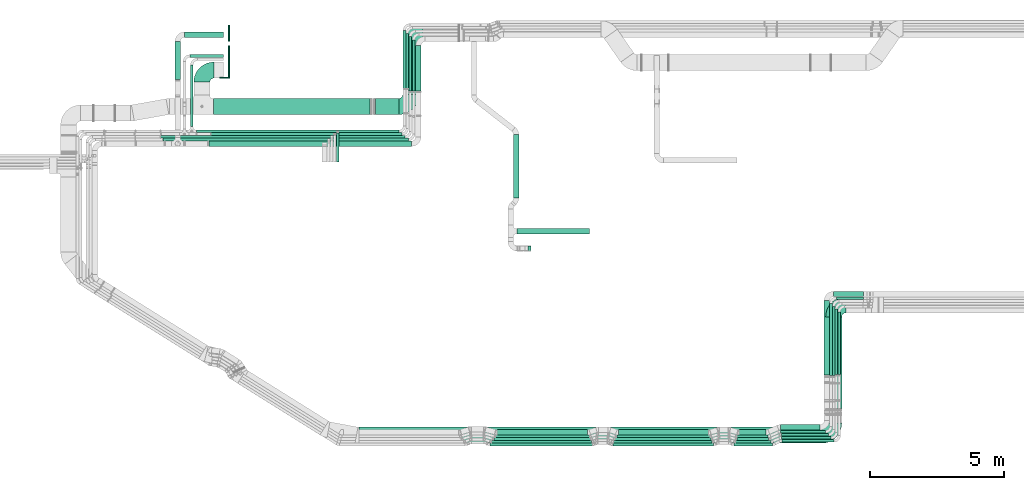
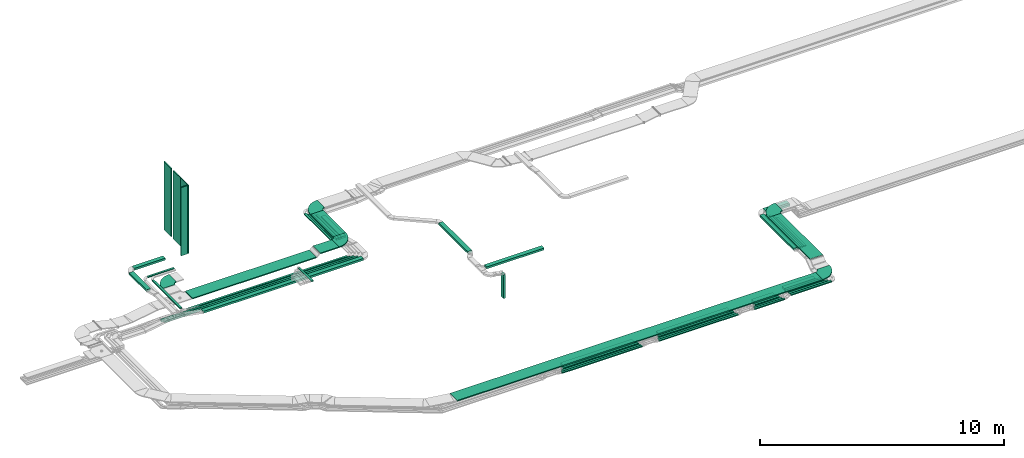
# One storey, part 5 of 38: 54 flow segments, 5 flow fittings.
"""IFC2X3 building model written with IfcOpenShell, lengths in millimetres."""

from ifc_helpers import new_model, entity, si_unit, converted_unit, derived_unit, direction, frame, frame_2d, origin, origin_2d_with_axis, place, context, subcontext, project, spatial, polyline, circle_curve, parameter, trimmed, segment, composite_curve, rectangle, outline, extrude, source, transform, mapped, material, type_object, type_shapes, element, save


model = new_model("IFC2X3")

# Units and contexts
model_context = context("Model", 3, precision=0.01, world=origin(), true_north=direction((6.12303176911189e-17, 1.0)))
body_context = subcontext(model_context, "Body", "Model", "MODEL_VIEW")
ifc_project = project(units=[si_unit("LENGTHUNIT", "METRE", prefix="MILLI"), si_unit("AREAUNIT", "SQUARE_METRE"), si_unit("VOLUMEUNIT", "CUBIC_METRE"), converted_unit("PLANEANGLEUNIT", "DEGREE", entity("IfcRatioMeasure", 0.0174532925199433), si_unit("PLANEANGLEUNIT", "RADIAN"), dimensions=[0, 0, 0, 0, 0, 0, 0]), si_unit("MASSUNIT", "GRAM", prefix="KILO"), derived_unit("MASSDENSITYUNIT", [(si_unit("MASSUNIT", "GRAM", prefix="KILO"), 1), (si_unit("LENGTHUNIT", "METRE"), -3)]), derived_unit("MOMENTOFINERTIAUNIT", [(si_unit("LENGTHUNIT", "METRE"), 4)]), si_unit("TIMEUNIT", "SECOND"), si_unit("FREQUENCYUNIT", "HERTZ"), si_unit("THERMODYNAMICTEMPERATUREUNIT", "DEGREE_CELSIUS"), derived_unit("THERMALTRANSMITTANCEUNIT", [(si_unit("MASSUNIT", "GRAM", prefix="KILO"), 1), (si_unit("THERMODYNAMICTEMPERATUREUNIT", "KELVIN"), -1), (si_unit("TIMEUNIT", "SECOND"), -3)]), derived_unit("VOLUMETRICFLOWRATEUNIT", [(si_unit("LENGTHUNIT", "METRE"), 3), (si_unit("TIMEUNIT", "SECOND"), -1)]), derived_unit("MASSFLOWRATEUNIT", [(si_unit("MASSUNIT", "GRAM", prefix="KILO"), 1), (si_unit("TIMEUNIT", "SECOND"), -1)]), derived_unit("ROTATIONALFREQUENCYUNIT", [(si_unit("TIMEUNIT", "SECOND"), -1)]), si_unit("ELECTRICCURRENTUNIT", "AMPERE"), si_unit("ELECTRICVOLTAGEUNIT", "VOLT"), si_unit("POWERUNIT", "WATT"), si_unit("FORCEUNIT", "NEWTON", prefix="KILO"), si_unit("ILLUMINANCEUNIT", "LUX"), si_unit("LUMINOUSFLUXUNIT", "LUMEN"), si_unit("LUMINOUSINTENSITYUNIT", "CANDELA"), derived_unit("USERDEFINED", [(si_unit("MASSUNIT", "GRAM", prefix="KILO"), -1), (si_unit("LENGTHUNIT", "METRE"), -2), (si_unit("TIMEUNIT", "SECOND"), 3), (si_unit("LUMINOUSFLUXUNIT", "LUMEN"), 1)]), derived_unit("LINEARVELOCITYUNIT", [(si_unit("LENGTHUNIT", "METRE"), 1), (si_unit("TIMEUNIT", "SECOND"), -1)]), si_unit("PRESSUREUNIT", "PASCAL"), derived_unit("USERDEFINED", [(si_unit("LENGTHUNIT", "METRE"), -2), (si_unit("MASSUNIT", "GRAM", prefix="KILO"), 1), (si_unit("TIMEUNIT", "SECOND"), -2)]), derived_unit("LINEARFORCEUNIT", [(si_unit("MASSUNIT", "GRAM", prefix="KILO"), 1), (si_unit("LENGTHUNIT", "METRE"), 1), (si_unit("TIMEUNIT", "SECOND"), -2), (si_unit("LENGTHUNIT", "METRE"), -1)]), derived_unit("PLANARFORCEUNIT", [(si_unit("MASSUNIT", "GRAM", prefix="KILO"), 1), (si_unit("LENGTHUNIT", "METRE"), 1), (si_unit("TIMEUNIT", "SECOND"), -2), (si_unit("LENGTHUNIT", "METRE"), -2)])], contexts=[model_context])

# Site, building, storey
site_placement = place(None, frame((0.0, -0.00077364408347762, 0.0)))
site = spatial("IfcSite", under=ifc_project, at=site_placement, CompositionType="ELEMENT")
building_placement = place(site_placement, origin())
building = spatial("IfcBuilding", under=site, at=building_placement, CompositionType="ELEMENT")
storey_placement = place(building_placement, frame((0.0, 0.0, 4200.0)))
storey = spatial("IfcBuildingStorey", under=building, at=storey_placement, CompositionType="ELEMENT", Elevation=4200.0)

# Flow segments
cable_carrier_segment_type_1 = type_object("IfcCableCarrierSegmentType", PredefinedType="CABLETRAYSEGMENT")
flow_segment_1_placement = place(storey_placement, frame((23478.9930091024, 13508.3552755497, 2524.49099867058)))
element("IfcFlowSegment", 1, at=flow_segment_1_placement, inside=storey, type_object=cable_carrier_segment_type_1, context=body_context, shape_type="SweptSolid", body=[
    extrude(rectangle(XDim=1696.30769414965, YDim=199.999999999998, at=frame_2d((1.08002495835535e-12, 0.0), x_axis=(1.0, 0.0))), frame((100.0, 848.153847074823, 0.0), z_axis=(0.0, 0.0, 1.0), x_axis=(0.0, 1.0, 0.0)), (0.0, 0.0, 1.0), 99.9999999999989),
])
flow_segment_2_placement = place(storey_placement, frame((23353.0702916724, 13504.7244445567, 2520.16463947554)))
element("IfcFlowSegment", 2, at=flow_segment_2_placement, inside=storey, type_object=cable_carrier_segment_type_1, context=body_context, shape_type="SweptSolid", body=[
    extrude(rectangle(XDim=1918.7534875651, YDim=100.000000000003, at=frame_2d((1.08002495835535e-12, 0.0), x_axis=(1.0, 0.0))), frame((50.0, 959.376743782549, 0.0), z_axis=(0.0, 0.0, 1.0), x_axis=(0.0, 1.0, 0.0)), (0.0, 0.0, 1.0), 99.9999999999989),
])
flow_segment_3_placement = place(storey_placement, frame((23228.8695134699, 13511.1389839764, 2524.49099867056)))
element("IfcFlowSegment", 3, at=flow_segment_3_placement, inside=storey, type_object=cable_carrier_segment_type_1, context=body_context, shape_type="SweptSolid", body=[
    extrude(rectangle(XDim=2032.33894814533, YDim=100.000000000003, at=frame_2d((-1.08002495835535e-12, -2.16715534406831e-12), x_axis=(1.0, 0.0))), frame((50.0, 1016.16947407267, 0.0), z_axis=(0.0, 0.0, 1.0), x_axis=(0.0, 1.0, 0.0)), (0.0, 0.0, 1.0), 99.9999999999989),
])
flow_segment_4_placement = place(storey_placement, frame((23113.0702916722, 13606.2775052059, 2524.49099867056)))
element("IfcFlowSegment", 4, at=flow_segment_4_placement, inside=storey, type_object=cable_carrier_segment_type_1, context=body_context, shape_type="SweptSolid", body=[
    extrude(rectangle(XDim=2063.38546449354, YDim=100.000000000003, at=origin_2d_with_axis()), frame((50.0, 1031.69273224677, 0.0), z_axis=(0.0, 0.0, 1.0), x_axis=(0.0, 1.0, 0.0)), (0.0, 0.0, 1.0), 50.0000000000005),
])
flow_segment_5_placement = place(storey_placement, frame((23008.8695134699, 13606.2775052059, 2524.49099867056)))
element("IfcFlowSegment", 5, at=flow_segment_5_placement, inside=storey, type_object=cable_carrier_segment_type_1, context=body_context, shape_type="SweptSolid", body=[
    extrude(rectangle(XDim=2172.30851294771, YDim=100.000000000003, at=frame_2d((1.02318153949454e-12, 0.0), x_axis=(1.0, 0.0))), frame((50.0, 1086.15425647386, 0.0), z_axis=(0.0, 0.0, 1.0), x_axis=(0.0, 1.0, 0.0)), (0.0, 0.0, 1.0), 50.0000000000005),
])
flow_segment_6_placement = place(storey_placement, frame((35501.0542946572, 551.657002272053, 2836.0)))
element("IfcFlowSegment", 6, at=flow_segment_6_placement, inside=storey, type_object=cable_carrier_segment_type_1, context=body_context, shape_type="SweptSolid", body=[
    extrude(rectangle(XDim=1159.34523094115, YDim=99.9999999999999, at=frame_2d((0.0, 3.19744231092045e-14), x_axis=(1.0, 0.0))), frame((579.672615470576, 50.0, 0.0)), (0.0, 0.0, 1.0), 99.9999999999989),
])
flow_segment_7_placement = place(storey_placement, frame((35490.2912244604, 446.657002272025, 2836.0)))
element("IfcFlowSegment", 7, at=flow_segment_7_placement, inside=storey, type_object=cable_carrier_segment_type_1, context=body_context, shape_type="SweptSolid", body=[
    extrude(rectangle(XDim=1189.84057568571, YDim=100.0, at=frame_2d((2.1600499167107e-12, 3.19744231092045e-14), x_axis=(1.0, 0.0))), frame((594.920287842853, 50.0, 0.0)), (0.0, 0.0, 1.0), 100.000000000001),
])
flow_segment_8_placement = place(storey_placement, frame((39160.3222600307, 2909.51894178568, 3025.0)))
element("IfcFlowSegment", 8, at=flow_segment_8_placement, inside=storey, type_object=cable_carrier_segment_type_1, context=body_context, shape_type="SweptSolid", body=[
    extrude(rectangle(XDim=2444.67483897861, YDim=99.9999999999946, at=frame_2d((-3.41060513164848e-13, -4.33075797445781e-12), x_axis=(1.0, 0.0))), frame((50.0, 1222.33741948931, 0.0), z_axis=(0.0, 0.0, 1.0), x_axis=(0.0, -1.0, 0.0)), (0.0, 0.0, 1.0), 49.9999999999995),
])
flow_segment_9_placement = place(storey_placement, frame((39265.3222600307, 2909.51894178567, 3025.0)))
element("IfcFlowSegment", 9, at=flow_segment_9_placement, inside=storey, type_object=cable_carrier_segment_type_1, context=body_context, shape_type="SweptSolid", body=[
    extrude(rectangle(XDim=2339.67483897862, YDim=99.9999999999946, at=frame_2d((-2.27373675443232e-13, 0.0), x_axis=(1.0, 0.0))), frame((50.0, 1169.83741948931, 0.0), z_axis=(0.0, 0.0, 1.0), x_axis=(0.0, -1.0, 0.0)), (0.0, 0.0, 1.0), 49.9999999999984),
])
flow_segment_10_placement = place(storey_placement, frame((38811.3840639797, 1634.43874820266, 3300.0)))
element("IfcFlowSegment", 10, at=flow_segment_10_placement, inside=storey, type_object=cable_carrier_segment_type_1, context=body_context, shape_type="SweptSolid", body=[
    extrude(rectangle(XDim=3431.21825406948, YDim=600.000000000002, at=origin_2d_with_axis()), frame((300.0, 1715.60912703474, 0.0), z_axis=(0.0, 0.0, 1.0), x_axis=(0.0, -1.0, 0.0)), (0.0, 0.0, 1.0), 49.9999999999995),
])
flow_segment_11_placement = place(storey_placement, frame((39103.8222600307, 5820.19378076425, 3025.0)))
element("IfcFlowSegment", 11, at=flow_segment_11_placement, inside=storey, type_object=cable_carrier_segment_type_1, context=body_context, shape_type="SweptSolid", body=[
    extrude(rectangle(XDim=1117.36076727557, YDim=200.0, at=origin_2d_with_axis()), frame((558.680383637785, 100.0, 0.0), z_axis=(0.0, 0.0, 1.0), x_axis=(-1.0, 0.0, 0.0)), (0.0, 0.0, 1.0), 99.9999999999989),
])
flow_segment_12_placement = place(storey_placement, frame((38752.8222600307, 2892.35417728222, 3025.202631248)))
element("IfcFlowSegment", 12, at=flow_segment_12_placement, inside=storey, type_object=cable_carrier_segment_type_1, context=body_context, shape_type="SweptSolid", body=[
    extrude(rectangle(XDim=2776.81466354588, YDim=199.999999999998, at=origin_2d_with_axis()), frame((100.0, 1388.47617211461, 0.960396155282621), z_axis=(0.0, -0.00069172506749642, 0.999999760758187), x_axis=(0.0, -0.999999760758187, -0.00069172506749642)), (0.0, 0.0, 1.0), 100.0),
])
flow_segment_13_placement = place(storey_placement, frame((15291.7657974395, 11954.0299176423, 2750.0)))
element("IfcFlowSegment", 13, at=flow_segment_13_placement, inside=storey, type_object=cable_carrier_segment_type_1, context=body_context, shape_type="SweptSolid", body=[
    extrude(rectangle(XDim=7566.10371603052, YDim=99.9999999999989, at=frame_2d((-1.13686837721616e-12, -1.08357767203415e-12), x_axis=(1.0, 0.0))), frame((3783.05185801526, 50.0, 0.0), z_axis=(0.0, 0.0, 1.0), x_axis=(-1.0, 0.0, 0.0)), (0.0, 0.0, 1.0), 49.9999999999995),
])
flow_segment_14_placement = place(storey_placement, frame((15831.6184277521, 11851.5299176423, 2750.0)))
element("IfcFlowSegment", 14, at=flow_segment_14_placement, inside=storey, type_object=cable_carrier_segment_type_1, context=body_context, shape_type="SweptSolid", body=[
    extrude(rectangle(XDim=7130.45186392018, YDim=99.9999999999989, at=frame_2d((-9.09494701772928e-13, 1.08357767203415e-12), x_axis=(1.0, 0.0))), frame((3565.22593196009, 50.0, 0.0), z_axis=(0.0, 0.0, 1.0), x_axis=(-1.0, 0.0, 0.0)), (0.0, 0.0, 1.0), 49.9999999999995),
])
flow_segment_15_placement = place(storey_placement, frame((13940.7972165627, 11748.9581146253, 2750.0037782218)))
element("IfcFlowSegment", 15, at=flow_segment_15_placement, inside=storey, type_object=cable_carrier_segment_type_1, context=body_context, shape_type="SweptSolid", body=[
    extrude(rectangle(XDim=9137.0713587031, YDim=99.9999999999989, at=frame_2d((2.27373675443232e-12, 0.0), x_axis=(1.0, 0.0))), frame((4568.53567854445, 50.0, 0.0858751280687159), z_axis=(1.87970794353878e-05, 0.0, 1.0), x_axis=(-1.0, 0.0, 1.87970794353878e-05)), (0.0, 0.0, 1.0), 99.9999999999995),
])
flow_segment_16_placement = place(storey_placement, frame((26523.2217591703, 646.657002272051, 2836.0)))
element("IfcFlowSegment", 16, at=flow_segment_16_placement, inside=storey, type_object=cable_carrier_segment_type_1, context=body_context, shape_type="SweptSolid", body=[
    extrude(rectangle(XDim=3385.56862737912, YDim=200.0, at=frame_2d((2.1600499167107e-12, 6.3948846218409e-14), x_axis=(1.0, 0.0))), frame((1692.78431368956, 100.0, 0.0)), (0.0, 0.0, 1.0), 99.9999999999989),
])
flow_segment_17_placement = place(storey_placement, frame((26257.068480989, 246.657002271992, 2836.0)))
element("IfcFlowSegment", 17, at=flow_segment_17_placement, inside=storey, type_object=cable_carrier_segment_type_1, context=body_context, shape_type="SweptSolid", body=[
    extrude(rectangle(XDim=3827.37771721429, YDim=100.0, at=frame_2d((0.0, 1.77635683940025e-14), x_axis=(1.0, 0.0))), frame((1913.68885860714, 50.0, 0.0)), (0.0, 0.0, 1.0), 50.0000000000005),
])
flow_segment_18_placement = place(storey_placement, frame((26323.7168104528, 346.657002271883, 2836.0)))
element("IfcFlowSegment", 18, at=flow_segment_18_placement, inside=storey, type_object=cable_carrier_segment_type_1, context=body_context, shape_type="SweptSolid", body=[
    extrude(rectangle(XDim=3735.72938775046, YDim=100.0, at=frame_2d((0.0, 3.19744231092045e-14), x_axis=(1.0, 0.0))), frame((1867.86469387523, 50.0, 0.0)), (0.0, 0.0, 1.0), 49.9999999999995),
])
flow_segment_19_placement = place(storey_placement, frame((26407.2862410283, 446.657002271935, 2836.0)))
element("IfcFlowSegment", 19, at=flow_segment_19_placement, inside=storey, type_object=cable_carrier_segment_type_1, context=body_context, shape_type="SweptSolid", body=[
    extrude(rectangle(XDim=3607.07536972812, YDim=100.0, at=origin_2d_with_axis()), frame((1803.53768486406, 50.0, 0.0)), (0.0, 0.0, 1.0), 100.000000000001),
])
flow_segment_20_placement = place(storey_placement, frame((26471.7904711044, 546.657002271971, 2836.0)))
element("IfcFlowSegment", 20, at=flow_segment_20_placement, inside=storey, type_object=cable_carrier_segment_type_1, context=body_context, shape_type="SweptSolid", body=[
    extrude(rectangle(XDim=3500.05490190336, YDim=100.0, at=frame_2d((2.1600499167107e-12, 6.75015598972095e-14), x_axis=(1.0, 0.0))), frame((1750.02745095168, 50.0, 0.0)), (0.0, 0.0, 1.0), 99.9999999999989),
])
flow_segment_21_placement = place(storey_placement, frame((31064.1527144664, 646.657002272071, 2836.0)))
element("IfcFlowSegment", 21, at=flow_segment_21_placement, inside=storey, type_object=cable_carrier_segment_type_1, context=body_context, shape_type="SweptSolid", body=[
    extrude(rectangle(XDim=3361.53433688883, YDim=200.0, at=frame_2d((-2.1600499167107e-12, 6.3948846218409e-14), x_axis=(1.0, 0.0))), frame((1680.76716844441, 100.0, 0.0)), (0.0, 0.0, 1.0), 100.000000000001),
])
flow_segment_22_placement = place(storey_placement, frame((30849.5379625914, 246.657002271967, 2836.0)))
element("IfcFlowSegment", 22, at=flow_segment_22_placement, inside=storey, type_object=cable_carrier_segment_type_1, context=body_context, shape_type="SweptSolid", body=[
    extrude(rectangle(XDim=3769.83343954607, YDim=100.0, at=frame_2d((2.1600499167107e-12, 0.0), x_axis=(1.0, 0.0))), frame((1884.91671977304, 50.0, 0.0)), (0.0, 0.0, 1.0), 49.9999999999995),
])
flow_segment_23_placement = place(storey_placement, frame((30877.2775419911, 346.657002271913, 2836.0)))
element("IfcFlowSegment", 23, at=flow_segment_23_placement, inside=storey, type_object=cable_carrier_segment_type_1, context=body_context, shape_type="SweptSolid", body=[
    extrude(rectangle(XDim=3689.36782997479, YDim=100.0, at=frame_2d((0.0, -3.19744231092045e-14), x_axis=(1.0, 0.0))), frame((1844.6839149874, 50.0, 0.0)), (0.0, 0.0, 1.0), 49.9999999999995),
])
flow_segment_24_placement = place(storey_placement, frame((30932.4665718533, 446.657002271958, 2836.0)))
element("IfcFlowSegment", 24, at=flow_segment_24_placement, inside=storey, type_object=cable_carrier_segment_type_1, context=body_context, shape_type="SweptSolid", body=[
    extrude(rectangle(XDim=3591.78366611905, YDim=100.0, at=frame_2d((0.0, -3.19744231092045e-14), x_axis=(1.0, 0.0))), frame((1795.89183305952, 50.0, 0.0)), (0.0, 0.0, 1.0), 99.9999999999989),
])
flow_segment_25_placement = place(storey_placement, frame((30999.9043044964, 546.657002272011, 2836.0)))
element("IfcFlowSegment", 25, at=flow_segment_25_placement, inside=storey, type_object=cable_carrier_segment_type_1, context=body_context, shape_type="SweptSolid", body=[
    extrude(rectangle(XDim=3479.44994453675, YDim=100.0, at=origin_2d_with_axis()), frame((1739.72497226838, 50.0, 0.0)), (0.0, 0.0, 1.0), 99.9999999999989),
])
flow_segment_26_placement = place(storey_placement, frame((35576.8901915957, 651.657002272097, 2836.0)))
element("IfcFlowSegment", 26, at=flow_segment_26_placement, inside=storey, type_object=cable_carrier_segment_type_1, context=body_context, shape_type="SweptSolid", body=[
    extrude(rectangle(XDim=1004.34018748789, YDim=200.0, at=frame_2d((0.0, 6.3948846218409e-14), x_axis=(1.0, 0.0))), frame((502.170093743948, 100.0, 0.0)), (0.0, 0.0, 1.0), 99.9999999999989),
])
flow_segment_27_placement = place(storey_placement, frame((35383.491247628, 246.657002271997, 2836.0)))
element("IfcFlowSegment", 27, at=flow_segment_27_placement, inside=storey, type_object=cable_carrier_segment_type_1, context=body_context, shape_type="SweptSolid", body=[
    extrude(rectangle(XDim=1441.96076120629, YDim=100.0, at=frame_2d((0.0, -3.5527136788005e-14), x_axis=(1.0, 0.0))), frame((720.980380603147, 50.0, 0.0)), (0.0, 0.0, 1.0), 49.9999999999995),
])
flow_segment_28_placement = place(storey_placement, frame((37174.4085359721, 378.109039852042, 2836.0)))
element("IfcFlowSegment", 28, at=flow_segment_28_placement, inside=storey, type_object=cable_carrier_segment_type_1, context=body_context, shape_type="SweptSolid", body=[
    extrude(rectangle(XDim=1939.91372405874, YDim=100.0, at=frame_2d((-4.32009983342141e-12, 3.19744231092045e-14), x_axis=(1.0, 0.0))), frame((969.956862029375, 50.0, 0.0)), (0.0, 0.0, 1.0), 49.9999999999995),
])
flow_segment_29_placement = place(storey_placement, frame((35441.779605389, 346.657002271956, 2836.0)))
element("IfcFlowSegment", 29, at=flow_segment_29_placement, inside=storey, type_object=cable_carrier_segment_type_1, context=body_context, shape_type="SweptSolid", body=[
    extrude(rectangle(XDim=1314.70372211323, YDim=100.0, at=frame_2d((0.0, 3.19744231092045e-14), x_axis=(1.0, 0.0))), frame((657.351861056617, 50.0, 0.0)), (0.0, 0.0, 1.0), 49.9999999999995),
])
flow_segment_30_placement = place(storey_placement, frame((37155.3058401518, 490.3472112638, 2836.0)))
element("IfcFlowSegment", 30, at=flow_segment_30_placement, inside=storey, type_object=cable_carrier_segment_type_1, context=body_context, shape_type="SweptSolid", body=[
    extrude(rectangle(XDim=1854.01641987895, YDim=100.0, at=origin_2d_with_axis()), frame((927.008209939475, 50.0, 0.0)), (0.0, 0.0, 1.0), 49.9999999999995),
])
flow_segment_31_placement = place(storey_placement, frame((37122.1963341853, 837.254288304499, 2836.0)))
element("IfcFlowSegment", 31, at=flow_segment_31_placement, inside=storey, type_object=cable_carrier_segment_type_1, context=body_context, shape_type="SweptSolid", body=[
    extrude(rectangle(XDim=1479.62592584546, YDim=200.0, at=origin_2d_with_axis()), frame((739.812962922728, 100.0, 0.0)), (0.0, 0.0, 1.0), 99.9999999999989),
])
flow_segment_32_placement = place(storey_placement, frame((37121.0041266084, 724.156672203177, 2836.0)))
element("IfcFlowSegment", 32, at=flow_segment_32_placement, inside=storey, type_object=cable_carrier_segment_type_1, context=body_context, shape_type="SweptSolid", body=[
    extrude(rectangle(XDim=1683.51813446421, YDim=100.0, at=frame_2d((4.32009983342141e-12, 0.0), x_axis=(1.0, 0.0))), frame((841.759067232099, 50.0, 0.0)), (0.0, 0.0, 1.0), 99.9999999999989),
])
flow_segment_33_placement = place(storey_placement, frame((39206.522261068, 5715.19378076428, 3025.0)))
element("IfcFlowSegment", 33, at=flow_segment_33_placement, inside=storey, type_object=cable_carrier_segment_type_1, context=body_context, shape_type="SweptSolid", body=[
    extrude(rectangle(XDim=1014.66076623827, YDim=100.000000000001, at=frame_2d((0.0, 5.43565192856477e-13), x_axis=(1.0, 0.0))), frame((507.330383119134, 50.0, 0.0), z_axis=(0.0, 0.0, 1.0), x_axis=(-1.0, 0.0, 0.0)), (0.0, 0.0, 1.0), 99.9999999999989),
])
flow_segment_34_placement = place(storey_placement, frame((38955.522261068, 2877.34862712167, 3025.0)))
element("IfcFlowSegment", 34, at=flow_segment_34_placement, inside=storey, type_object=cable_carrier_segment_type_1, context=body_context, shape_type="SweptSolid", body=[
    extrude(rectangle(XDim=2686.84515364263, YDim=99.9999999999989, at=frame_2d((0.0, 2.16715534406831e-12), x_axis=(1.0, 0.0))), frame((50.0, 1343.42257682132, 0.0), z_axis=(0.0, 0.0, 1.0), x_axis=(0.0, -1.0, 0.0)), (0.0, 0.0, 1.0), 99.9999999999989),
])
flow_segment_35_placement = place(storey_placement, frame((37150.1247583655, 610.764076237519, 2836.0)))
element("IfcFlowSegment", 35, at=flow_segment_35_placement, inside=storey, type_object=cable_carrier_segment_type_1, context=body_context, shape_type="SweptSolid", body=[
    extrude(rectangle(XDim=1757.69750166517, YDim=100.0, at=origin_2d_with_axis()), frame((878.848750832586, 50.0, 0.0)), (0.0, 0.0, 1.0), 99.9999999999989),
])
flow_segment_36_placement = place(storey_placement, frame((39058.8222600307, 2877.34862712169, 3025.0)))
element("IfcFlowSegment", 36, at=flow_segment_36_placement, inside=storey, type_object=cable_carrier_segment_type_1, context=body_context, shape_type="SweptSolid", body=[
    extrude(rectangle(XDim=2581.84515364261, YDim=99.9999999999946, at=frame_2d((-5.6843418860808e-13, -4.33075797445781e-12), x_axis=(1.0, 0.0))), frame((50.0, 1290.9225768213, 0.0), z_axis=(0.0, 0.0, 1.0), x_axis=(0.0, -1.0, 0.0)), (0.0, 0.0, 1.0), 100.000000000001),
])
flow_segment_37_placement = place(storey_placement, frame((21352.5251693285, 341.65700227203, 3108.85255784634)))
element("IfcFlowSegment", 37, at=flow_segment_37_placement, inside=storey, type_object=cable_carrier_segment_type_1, context=body_context, shape_type="SweptSolid", body=[
    extrude(rectangle(XDim=17307.8588946513, YDim=600.0, at=origin_2d_with_axis()), frame((8653.92944732565, 300.0, 0.0)), (0.0, 0.0, 1.0), 49.9999999999995),
])
flow_segment_38_placement = place(storey_placement, frame((15914.0814441513, 12632.0485020162, 2682.77089996955)))
element("IfcFlowSegment", 38, at=flow_segment_38_placement, inside=storey, type_object=cable_carrier_segment_type_1, context=body_context, shape_type="SweptSolid", body=[
    extrude(rectangle(XDim=5857.91074407675, YDim=599.999999999998, at=frame_2d((-1.13686837721616e-12, 0.0), x_axis=(1.0, 0.0))), frame((2928.95537203837, 300.0, 0.0)), (0.0, 0.0, 1.0), 49.9999999999995),
])
flow_segment_39_placement = place(storey_placement, frame((22998.9930091024, 13383.0485020161, 2823.51525104152)))
element("IfcFlowSegment", 39, at=flow_segment_39_placement, inside=storey, type_object=cable_carrier_segment_type_1, context=body_context, shape_type="SweptSolid", body=[
    extrude(rectangle(XDim=1845.29649822984, YDim=600.000000000002, at=frame_2d((0.0, 2.1600499167107e-12), x_axis=(1.0, 0.0))), frame((300.0, 922.648249114922, 0.0), z_axis=(0.0, 0.0, 1.0), x_axis=(0.0, -1.0, 0.0)), (0.0, 0.0, 1.0), 49.9999999999995),
])
flow_segment_40_placement = place(storey_placement, frame((15034.0702916724, 14768.1251604397, 2750.0)))
element("IfcFlowSegment", 40, at=flow_segment_40_placement, inside=storey, type_object=cable_carrier_segment_type_1, context=body_context, shape_type="SweptSolid", body=[
    extrude(rectangle(XDim=1263.23547445559, YDim=99.9999999999989, at=origin_2d_with_axis()), frame((631.617737227794, 50.0, 0.0)), (0.0, 0.0, 1.0), 49.9999999999984),
])
flow_segment_41_placement = place(storey_placement, frame((14834.5407015969, 15518.1251604396, 2753.81871708571)))
element("IfcFlowSegment", 41, at=flow_segment_41_placement, inside=storey, type_object=cable_carrier_segment_type_1, context=body_context, shape_type="SweptSolid", body=[
    extrude(rectangle(XDim=1462.76506453108, YDim=200.000000000002, at=frame_2d((1.08002495835535e-12, 0.0), x_axis=(1.0, 0.0))), frame((731.382532265539, 100.0, 0.0)), (0.0, 0.0, 1.0), 99.9999999999978),
])
flow_segment_42_placement = place(storey_placement, frame((15061.7657974395, 12184.0299176424, 2750.0)))
element("IfcFlowSegment", 42, at=flow_segment_42_placement, inside=storey, type_object=cable_carrier_segment_type_1, context=body_context, shape_type="SweptSolid", body=[
    extrude(rectangle(XDim=2308.09524279726, YDim=99.9999999999989, at=frame_2d((-1.02318153949454e-12, 0.0), x_axis=(1.0, 0.0))), frame((50.0, 1154.04762139864, 0.0), z_axis=(0.0, 0.0, 1.0), x_axis=(0.0, 1.0, 0.0)), (0.0, 0.0, 1.0), 49.9999999999995),
])
flow_segment_43_placement = place(storey_placement, frame((14483.5407015969, 13939.0808919128, 2753.81871708571)))
element("IfcFlowSegment", 43, at=flow_segment_43_placement, inside=storey, type_object=cable_carrier_segment_type_1, context=body_context, shape_type="SweptSolid", body=[
    extrude(rectangle(XDim=1428.04426852684, YDim=200.000000000002, at=frame_2d((1.08002495835535e-12, -2.16715534406831e-12), x_axis=(1.0, 0.0))), frame((100.0, 714.022134263417, 0.0), z_axis=(0.0, 0.0, 1.0), x_axis=(0.0, -1.0, 0.0)), (0.0, 0.0, 1.0), 99.9999999999989),
])
flow_segment_44_placement = place(storey_placement, frame((21968.300031161, 12632.0485020161, 2823.51525104151)))
element("IfcFlowSegment", 44, at=flow_segment_44_placement, inside=storey, type_object=cable_carrier_segment_type_1, context=body_context, shape_type="SweptSolid", body=[
    extrude(rectangle(XDim=879.692977941358, YDim=599.999999999998, at=origin_2d_with_axis()), frame((439.846488970683, 300.0, 0.0)), (0.0, 0.0, 1.0), 49.9999999999984),
])
flow_segment_45_placement = place(storey_placement, frame((15744.8896827201, 11443.7857236441, 2750.0)))
element("IfcFlowSegment", 45, at=flow_segment_45_placement, inside=storey, type_object=cable_carrier_segment_type_1, context=body_context, shape_type="SweptSolid", body=[
    extrude(rectangle(XDim=7583.10332638238, YDim=200.000000000002, at=origin_2d_with_axis()), frame((3791.55166319119, 100.0, 0.0), z_axis=(0.0, 0.0, 1.0), x_axis=(-1.0, 0.0, 0.0)), (0.0, 0.0, 1.0), 99.9999999999989),
])
flow_segment_46_placement = place(storey_placement, frame((14029.7367046138, 11646.8541189971, 2750.0)))
element("IfcFlowSegment", 46, at=flow_segment_46_placement, inside=storey, type_object=cable_carrier_segment_type_1, context=body_context, shape_type="SweptSolid", body=[
    extrude(rectangle(XDim=9172.33358705854, YDim=99.9999999999989, at=origin_2d_with_axis()), frame((4586.16679352927, 50.0, 0.0), z_axis=(0.0, 0.0, 1.0), x_axis=(-1.0, 0.0, 0.0)), (0.0, 0.0, 1.0), 99.9999999999989),
])
flow_segment_47_placement = place(storey_placement, frame((20510.9642990801, 10851.673044066, 3005.0)))
element("IfcFlowSegment", 47, at=flow_segment_47_placement, inside=storey, type_object=cable_carrier_segment_type_1, context=body_context, shape_type="SweptSolid", body=[
    extrude(rectangle(XDim=1092.35687357644, YDim=100.000000000003, at=origin_2d_with_axis()), frame((50.0, 546.17843678822, 0.0), z_axis=(0.0, 0.0, 1.0), x_axis=(0.0, -1.0, 0.0)), (0.0, 0.0, 1.0), 50.0000000000005),
])
flow_segment_48_placement = place(storey_placement, frame((27134.0582634393, 9508.58330823558, 2930.0)))
element("IfcFlowSegment", 48, at=flow_segment_48_placement, inside=storey, type_object=cable_carrier_segment_type_1, context=body_context, shape_type="SweptSolid", body=[
    extrude(rectangle(XDim=2372.51346226528, YDim=199.999999999998, at=origin_2d_with_axis()), frame((100.0, 1186.25673113264, 0.0), z_axis=(0.0, 0.0, 1.0), x_axis=(0.0, -1.0, 0.0)), (0.0, 0.0, 1.0), 99.9999999999989),
])
flow_segment_49_placement = place(storey_placement, frame((27261.2155509647, 8163.79521991052, 2930.0)))
element("IfcFlowSegment", 49, at=flow_segment_49_placement, inside=storey, type_object=cable_carrier_segment_type_1, context=body_context, shape_type="SweptSolid", body=[
    extrude(rectangle(XDim=2723.62339400056, YDim=200.0, at=frame_2d((-2.1600499167107e-12, 0.0), x_axis=(1.0, 0.0))), frame((1361.81169700028, 100.0, 0.0)), (0.0, 0.0, 1.0), 100.0),
])
flow_segment_50_placement = place(storey_placement, frame((27686.2155509648, 7525.00077377345, 1680.0)))
element("IfcFlowSegment", 50, at=flow_segment_50_placement, inside=storey, type_object=cable_carrier_segment_type_1, context=body_context, shape_type="SweptSolid", body=[
    extrude(rectangle(XDim=100.000000000003, YDim=200.0, at=origin_2d_with_axis()), frame((50.0, 100.0, 0.0)), (0.0, 0.0, 1.0), 1186.96103583828),
])

# Flow fittings
ifc_material = material()
cable_carrier_fitting_type = type_object("IfcCableCarrierFittingType", Name="470_DKC_S5_Variable Angle Elbow 0-45:-", PredefinedType="NOTDEFINED", material=ifc_material)
shared_shape = source(origin(), body_context, "Body", "SweptSolid", [
    extrude(outline(composite_curve([segment(polyline([(-225.750000000019, -525.249999999993), (-224.750000000017, -525.249999999993)]), True, "CONTINUOUS"), segment(trimmed(circle_curve(frame_2d((-224.749999999992, 224.750000000007), x_axis=(0.0, -1.0)), 750.0), [parameter(0.0)], [parameter(90.0)], True, "PARAMETER"), True, "CONTINUOUS"), segment(polyline([(525.250000000007, 224.749999999983), (525.250000000007, 225.749999999979)]), True, "CONTINUOUS"), segment(polyline([(525.250000000007, 225.749999999979), (-74.7499999999926, 225.750000000006)]), True, "CONTINUOUS"), segment(polyline([(-74.7499999999926, 225.750000000006), (-74.7499999999927, 224.750000000002)]), True, "CONTINUOUS"), segment(trimmed(circle_curve(frame_2d((-224.749999999992, 224.750000000007), x_axis=(0.0, -1.0)), 150.0), [parameter(0.0)], [parameter(90.0000000000001)], True, "PARAMETER"), False, "CONTINUOUS"), segment(polyline([(-224.749999999996, 74.750000000007), (-225.749999999998, 74.750000000007)]), True, "CONTINUOUS"), segment(polyline([(-225.749999999998, 74.750000000007), (-225.750000000019, -525.249999999993)]), True, "CONTINUOUS")], self_intersect=False)), frame((-225.24999999999, 225.249999999992, -25.0)), (0.0, 0.0, 1.0), 50.0000000000082),
])
type_shapes(cable_carrier_fitting_type, [shared_shape])
for number, where, z_axis, x_axis, name in (
    (51, (23298.9930091024, 15679.3450002459, 2848.51525104152), (0.0, 0.0, 1.0), (-1.0, 0.0, 0.0), "470_DKC_S5_Variable Angle Elbow 0-45:-"),
    (52, (39111.3840639798, 5516.65700227212, 3325.0), (0.0, 0.0, 1.0), (-1.0, 0.0, 0.0), "470_DKC_S5_Variable Angle Elbow 0-45:-"),
):
    element("IfcFlowFitting", number, at=place(storey_placement, frame(where, z_axis=z_axis, x_axis=x_axis)), inside=storey, type_object=cable_carrier_fitting_type, material=ifc_material, Name=name, ObjectType="470_DKC_S5_Variable Angle Elbow 0-45:-", context=body_context, shape_type="MappedRepresentation", body=[
        mapped(shared_shape, transform((0.0, 0.0, 0.0), scale=1.0)),
    ])
flow_fitting_1_placement = place(storey_placement, frame((39111.3840639797, 641.657002272047, 3133.85255784634)))
element("IfcFlowFitting", 53, at=flow_fitting_1_placement, inside=storey, type_object=cable_carrier_fitting_type, material=ifc_material, Name="470_DKC_S5_Variable Angle Elbow 0-45:-", ObjectType="470_DKC_S5_Variable Angle Elbow 0-45:-", context=body_context, shape_type="MappedRepresentation", body=[
    mapped(shared_shape, transform((0.0, 0.0, 0.0), scale=1.0)),
])
flow_fitting_2_placement = place(storey_placement, frame((15484.0814441513, 14292.0485020162, 2707.77089996955), z_axis=(0.0, 0.0, 1.0), x_axis=(-1.0, 0.0, 0.0)))
element("IfcFlowFitting", 54, at=flow_fitting_2_placement, inside=storey, type_object=cable_carrier_fitting_type, material=ifc_material, Name="470_DKC_S5_Variable Angle Elbow 0-45:-", ObjectType="470_DKC_S5_Variable Angle Elbow 0-45:-", context=body_context, shape_type="MappedRepresentation", body=[
    mapped(shared_shape, transform((0.0, 0.0, 0.0), scale=1.0)),
])
flow_fitting_3_placement = place(storey_placement, frame((23298.9930091024, 12932.0485020161, 2848.51525104152)))
element("IfcFlowFitting", 55, at=flow_fitting_3_placement, inside=storey, type_object=cable_carrier_fitting_type, material=ifc_material, Name="470_DKC_S5_Variable Angle Elbow 0-45:-", ObjectType="470_DKC_S5_Variable Angle Elbow 0-45:-", context=body_context, shape_type="MappedRepresentation", body=[
    mapped(shared_shape, transform((0.0, 0.0, 0.0), scale=1.0)),
])

# Flow segments
cable_carrier_segment_type_2 = type_object("IfcCableCarrierSegmentType", PredefinedType="CABLETRAYSEGMENT")
for number, where in (
    (56, (16472.305766128, 15367.6093717678, 3945.84199571756)),
    (57, (16472.305766128, 14607.6093717678, 3945.84199571756)),
):
    element("IfcFlowSegment", number, at=place(storey_placement, frame(where)), inside=storey, type_object=cable_carrier_segment_type_2, context=body_context, shape_type="SweptSolid", body=[
        extrude(rectangle(XDim=50.0000000000016, YDim=600.000000000002, at=origin_2d_with_axis()), frame((25.0, 300.0, 0.0), z_axis=(0.0, 0.0, 1.0), x_axis=(-1.0, 0.0, 0.0)), (0.0, 0.0, 1.0), 3420.0),
    ])
flow_segment_51_placement = place(storey_placement, frame((16472.305766128, 13987.6093717678, 3945.84199571756)))
element("IfcFlowSegment", 58, at=flow_segment_51_placement, inside=storey, type_object=cable_carrier_segment_type_2, context=body_context, shape_type="SweptSolid", body=[
    extrude(rectangle(XDim=50.0000000000016, YDim=599.999999999998, at=origin_2d_with_axis()), frame((25.0, 300.0, 0.0), z_axis=(0.0, 0.0, 1.0), x_axis=(-1.0, 0.0, 0.0)), (0.0, 0.0, 1.0), 3420.0),
])
flow_segment_52_placement = place(storey_placement, frame((16147.305766128, 13982.6093717678, 3945.84199571756)))
element("IfcFlowSegment", 59, at=flow_segment_52_placement, inside=storey, type_object=cable_carrier_segment_type_2, context=body_context, shape_type="SweptSolid", body=[
    extrude(rectangle(XDim=50.0000000000016, YDim=300.000000000001, at=origin_2d_with_axis()), frame((150.0, 25.0, 0.0), z_axis=(0.0, 0.0, 1.0), x_axis=(0.0, 1.0, 0.0)), (0.0, 0.0, 1.0), 3420.0),
])

save(model, "model.ifc")
